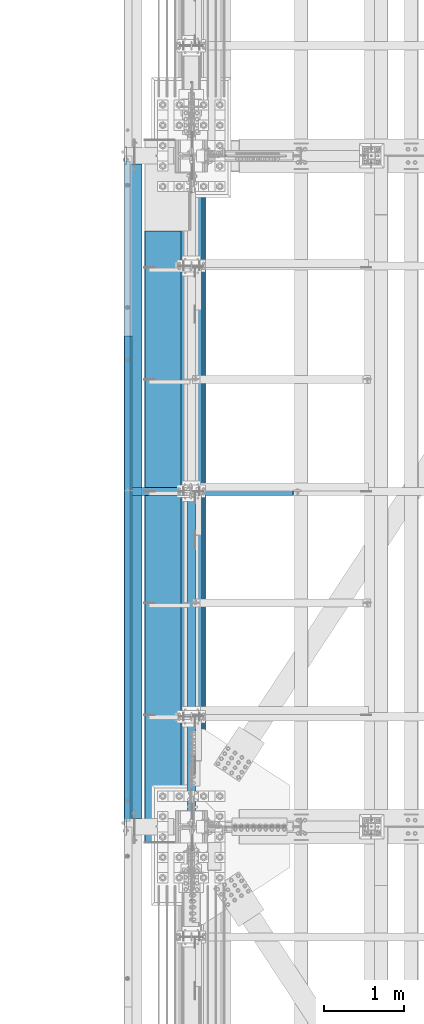
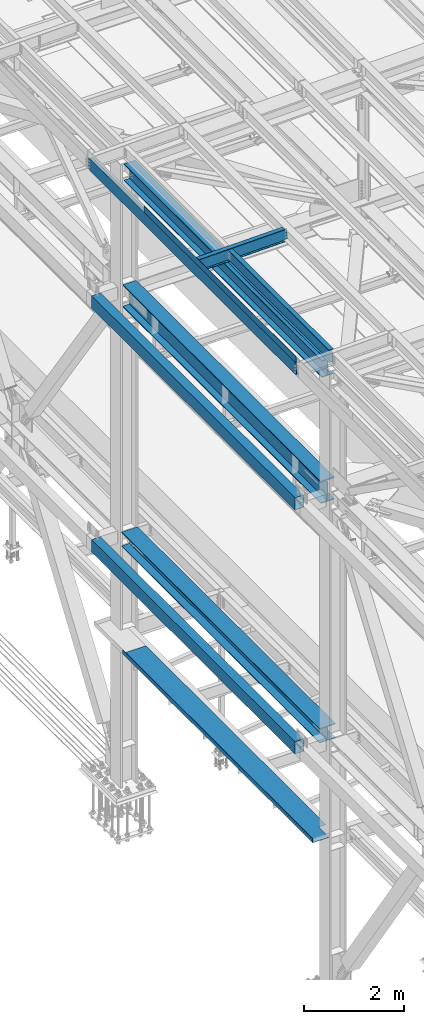
# One storey, part 1818 of 3843: 10 beams, 9 elements without a shape of their own.
"""IFC2X3 building model written with IfcOpenShell, lengths in millimetres."""

from ifc_helpers import new_model, si_unit, frame, origin_with_axes, place, context, subcontext, project, spatial, faceted_brep, material, type_object, element, aggregate, save


model = new_model("IFC2X3")

# Units and contexts
model_context = context("Model", 3, precision=1e-05, world=origin_with_axes())
body_context = subcontext(model_context, "Body", "Model", "MODEL_VIEW")
ifc_project = project(units=[si_unit("LENGTHUNIT", "METRE", prefix="MILLI"), si_unit("AREAUNIT", "SQUARE_METRE"), si_unit("VOLUMEUNIT", "CUBIC_METRE"), si_unit("MASSUNIT", "GRAM", prefix="KILO"), si_unit("TIMEUNIT", "SECOND"), si_unit("PLANEANGLEUNIT", "RADIAN"), si_unit("SOLIDANGLEUNIT", "STERADIAN"), si_unit("THERMODYNAMICTEMPERATUREUNIT", "DEGREE_CELSIUS"), si_unit("LUMINOUSINTENSITYUNIT", "LUMEN")], contexts=[model_context])

# Site, building, storey
site_placement = place(None, origin_with_axes())
site = spatial("IfcSite", under=ifc_project, at=site_placement, CompositionType="ELEMENT")
building_placement = place(site_placement, origin_with_axes())
building = spatial("IfcBuilding", under=site, at=building_placement, Name="Undefined", CompositionType="ELEMENT")
storey_placement = place(building_placement, origin_with_axes())
storey = spatial("IfcBuildingStorey", under=building, at=storey_placement, Name="Undefined", CompositionType="ELEMENT", Elevation=0.0)

# Assembly, beams
assembly_1_placement = place(storey_placement, origin_with_axes())
assembly_1 = element("IfcElementAssembly", 1, at=assembly_1_placement, inside=storey, Name="BEAM", AssemblyPlace="NOTDEFINED", PredefinedType="RIGID_FRAME")
ifc_material_1 = material(Name="STEEL/A572-50")
beam_type_1 = type_object("IfcBeamType", Name="C12X20.7", PredefinedType="NOTDEFINED")
beam_1_placement = place(assembly_1_placement, frame((35779.1150555635, 58915.2999999999, 45560.3009647419), z_axis=(-0.0211520980073474, 0.0, 0.999776269347241), x_axis=(0.0, 1.0, 0.0)))
beam_1 = element("IfcBeam", 2, at=beam_1_placement, type_object=beam_type_1, material=ifc_material_1, Name="BEAM", ObjectType="C12X20.7", context=body_context, shape_type="Brep", body=[
    faceted_brep([(15.8750000000582, 30.1624999998166, -126.999999999382), (15.8750003662499, 38.1000000000058, -127.000000023749), (53.975000190796, 38.0999999998094, -126.999999999396), (53.975000190796, 30.1624999998166, -126.999999999382), (58.8350797088351, 38.0999999998094, -127.96672992198), (58.8350797088351, 30.1624999998166, -127.966729921965), (62.955256176996, 38.0999999998021, -130.719743822439), (62.955256176996, 30.1624999998166, -130.719743822439), (65.7082700774772, 38.0999999997948, -134.839920290578), (65.7082700774772, 30.1624999998094, -134.6749274998), (66.6750000000611, 1.14757131086662e-06, -139.699999808552), (66.6750000000611, 38.0999999997948, -139.699999808603), (66.6750000000611, 38.0999999997803, -152.399999999783), (66.6750000000611, -38.1000000000931, -152.39999999971), (66.6750000000611, -38.1000000000931, -146.047459999718), (8289.92500000005, -38.0999999997948, 146.047459999805), (8289.92500000005, -38.0999999997875, 152.399999999798), (66.6750000000611, -38.0999999997875, 152.399999999798), (66.6750000000611, -38.0999999997948, 146.047459999805), (8289.92500000005, 38.1000000000859, 152.399999999725), (66.6750000000611, 38.1000000000859, 152.399999999725), (53.975000190796, 30.1625000000713, 126.999999999265), (53.975000190796, 38.100000000064, 126.999999999258), (15.8750006201954, 38.1000000000058, 126.999999975014), (15.8750000000582, 30.1625000000713, 126.999999999265), (58.8350797088351, 30.1625000000786, 127.966729921849), (58.8350797088351, 38.100000000064, 127.966729921842), (62.955256176996, 30.1625000000786, 130.719743822316), (62.955256176996, 38.1000000000568, 130.719743822301), (65.7082700774772, 30.1625000000786, 134.674927499756), (65.7082700774772, 38.1000000000713, 134.83992029044), (66.6750000000611, 1.1482770787552e-06, 139.699999808494), (66.6750000000611, 38.1000000000713, 139.699999808465), (8290.89172992263, 30.1625000000786, 134.674927499756), (8289.92500000005, 1.1482770787552e-06, 139.699999808494), (8289.92500000005, 38.1000000000713, 139.699999808465), (8290.89172992263, 38.1000000000713, 134.83992029044), (8293.64474382311, 30.1625000000786, 130.719743822316), (8293.64474382311, 38.1000000000568, 130.719743822301), (8297.76492029126, 30.1625000000786, 127.966729921849), (8297.76492029126, 38.100000000064, 127.966729921842), (8302.62499980931, 30.1625000000713, 126.999999999265), (8302.62499980931, 38.100000000064, 126.999999999258), (8340.72500000005, 30.1625000000713, 126.999999999265), (8340.72500000005, 38.100000000064, 126.999999999258), (8340.72500000005, 30.162500000064, 114.299999983516), (8340.72500000005, 30.1624999998385, -116.300000010502), (8340.72500000005, 30.1624999998166, -126.999999999382), (8340.72500000005, 38.0999999998094, -126.999999999396), (8302.62499980931, 30.1624999998166, -126.999999999382), (8302.62499980931, 38.0999999998094, -126.999999999396), (8297.76492029126, 30.1624999998166, -127.966729921965), (8297.76492029126, 38.0999999998094, -127.96672992198), (8293.64474382311, 30.1624999998166, -130.719743822439), (8293.64474382311, 38.0999999998021, -130.719743822439), (8290.89172992263, 30.1624999998094, -134.6749274998), (8290.89172992263, 38.0999999997948, -134.839920290578), (8289.92500000005, 1.14757131086662e-06, -139.699999808552), (8289.92500000005, 38.0999999997948, -139.699999808603), (8289.92500000005, -38.1000000000931, -146.047459999718), (8289.92500000005, -38.1000000000931, -152.39999999971), (8289.92500000005, 38.0999999997803, -152.399999999783), (15.8750000000582, 30.1624999998312, -116.299999999967), (15.8750000000582, 30.1625000000568, 114.299999994066)], [[[0, 1, 2, 3]], [[3, 2, 4, 5]], [[5, 4, 6, 7]], [[7, 6, 8, 9]], [[10, 11, 12, 13, 14]], [[9, 8, 11, 10]], [[15, 16, 17, 18]], [[16, 19, 20, 17]], [[21, 22, 23, 24]], [[25, 26, 22, 21]], [[27, 28, 26, 25]], [[29, 30, 28, 27]], [[31, 32, 30, 29]], [[17, 20, 32, 31, 18]], [[29, 33, 34, 15, 18, 31]], [[16, 15, 34, 35, 19]], [[33, 36, 35, 34]], [[37, 38, 36, 33]], [[39, 40, 38, 37]], [[41, 42, 40, 39]], [[43, 44, 42, 41]], [[44, 43, 45, 46, 47, 48]], [[47, 49, 50, 48]], [[51, 52, 50, 49]], [[53, 54, 52, 51]], [[55, 56, 54, 53]], [[57, 58, 56, 55]], [[59, 60, 61, 58, 57]], [[60, 59, 14, 13]], [[61, 60, 13, 12]], [[6, 4, 2, 1, 23, 22, 26, 28, 30, 32, 20, 19, 35, 36, 38, 40, 42, 44, 48, 50, 52, 54, 56, 58, 61, 12, 11, 8]], [[62, 63, 24, 23, 1, 0]], [[55, 53, 51, 49, 47, 46, 45, 43, 41, 39, 37, 33, 29, 27, 25, 21, 24, 63, 62, 0, 3, 5, 7, 9]], [[59, 57, 55, 9, 10, 14]]]),
])
ifc_material_2 = material(Name="STEEL/A36")
beam_type_2 = type_object("IfcBeamType", PredefinedType="NOTDEFINED")
beam_2_placement = place(assembly_1_placement, frame((35839.3101110204, 61979.175, 45717.1843160684), z_axis=(0.0, -1.0, 0.0), x_axis=(-0.999776270257024, 0.0, -0.0211520550054595)))
beam_2 = element("IfcBeam", 3, at=beam_2_placement, type_object=beam_type_2, material=ifc_material_2, Name="BENT_PLATE", context=body_context, shape_type="Brep", body=[
    faceted_brep([(-3.50355549016967e-07, -3.17499999742722, -3048.00000001723), (3.50421032635495e-07, -3.17500000260043, 3048.00000001724), (3.5035191103816e-07, 3.17499999739084, 3048.00000001724), (-3.50424670614302e-07, 3.17500000256405, -3048.00000001723), (101.599999864371, 3.17499999856227, 3048.00000000522), (101.599998739839, 3.17500000373548, -3048.00000002925), (95.249998765099, -3.17499999632128, -3048.00000002851), (95.2499998896274, -3.17500000149448, 3048.00000000597), (101.600000309205, -161.925000875126, 3047.9999999938), (101.599999608374, -161.925000446165, -3048.00000004067), (95.2500003092064, -161.925000900388, 3047.99999999456), (95.2499996083752, -161.925000471427, -3048.00000003992)], [[[0, 1, 2, 3]], [[3, 2, 4, 5]], [[1, 0, 6, 7]], [[5, 4, 8, 9]], [[4, 2, 1, 7, 10, 8]], [[7, 6, 11, 10]], [[6, 0, 3, 5, 9, 11]], [[10, 11, 9, 8]]]),
])
aggregate(assembly_1, [beam_2, beam_1])

# Assembly, beam
assembly_2_placement = place(storey_placement, origin_with_axes())
assembly_2 = element("IfcElementAssembly", 4, at=assembly_2_placement, inside=storey, Name="BEAM", AssemblyPlace="NOTDEFINED", PredefinedType="RIGID_FRAME")
ifc_material_3 = material(Name="STEEL/A992")
beam_type_3 = type_object("IfcBeamType", Name="W21X101", PredefinedType="NOTDEFINED")
beam_3_placement = place(assembly_2_placement, frame((36576.0, 58915.3, 42197.3375), z_axis=(0.0, 0.0, 1.0), x_axis=(0.0, 1.0, 0.0)))
beam_3 = element("IfcBeam", 5, at=beam_3_placement, type_object=beam_type_3, material=ifc_material_3, Name="BEAM", ObjectType="W21X101", context=body_context, shape_type="Brep", body=[
    faceted_brep([(221.464601116095, -155.574999999997, 271.462500000001), (221.464601116095, 155.574999999997, 271.462500000001), (209.550000000017, 155.574999999997, 250.824999999997), (209.550000000017, 6.34999999999854, 250.824999999997), (209.550000000017, -6.34999999999854, 250.824999999997), (209.550000000017, -155.574999999997, 250.824999999997), (8143.87499999999, 6.34999999999854, -250.824999999997), (8143.87499999999, 147.637499999997, -250.824999999997), (8143.87499999999, 155.574999999997, -250.824999999997), (212.724999999999, 155.574999999997, -250.824999999997), (212.724999999999, 6.34999999999854, -250.824999999997), (8143.87499999999, -155.574999999997, -271.462500000001), (8143.87499999999, -155.574999999997, -250.824999999997), (212.724999999999, -155.574999999997, -250.824999999997), (212.724999999999, -155.574999999997, -271.462500000001), (8143.87499999999, 155.574999999997, -271.462500000001), (8143.87499999999, 147.637499999997, -271.462500000001), (8143.87499999999, -147.637499999997, -271.462500000001), (212.724999999999, 155.574999999997, -271.462500000001), (8143.87499999999, 6.34999999999854, 250.824999999997), (8143.87499999999, 147.637499999997, 250.824999999997), (8143.87499999999, 155.574999999997, 250.824999999997), (8143.87499999999, 155.574999999997, 271.462500000001), (8143.87499999999, 147.637499999997, 271.462500000001), (8143.87499999999, -147.637499999997, 271.462500000001), (8143.87499999999, -155.574999999997, 271.462500000001), (8143.87499999999, -155.574999999997, 250.824999999997), (8143.87499999999, -147.637499999997, 250.824999999997), (8143.87499999999, -6.34999999999854, 250.824999999997), (8143.87499999999, -6.34999999999854, 215.052499999998), (8143.87499999999, -6.34999999999854, -180.127499999995), (8143.87499999999, -6.34999999999854, -250.824999999997), (8143.87499999999, -147.637499999997, -250.824999999997), (209.550000000017, 6.34999999999854, 250.428), (209.550000000017, -6.34999999999854, 250.428), (244.474999999999, 6.34999999999854, 250.428), (244.474999999999, -6.34999999999854, 250.428), (289.859905435071, 6.34999999999854, 234.406795689014), (289.859905435071, -6.34999999999854, 234.406795689014), (294.149267898792, 6.34999999999854, 231.347328818971), (294.149267898792, -6.34999999999854, 231.347328818971), (296.156122181892, 6.34999999999854, 226.475829690324), (296.156122181892, -6.34999999999854, 226.475829690324), (295.266438807761, 6.34999999999854, 221.282812131351), (295.266438807761, -6.34999999999854, 221.282812131351), (291.752430772212, 6.34999999999854, 217.357163726287), (291.752430772212, -6.34999999999854, 217.357163726287), (286.689265581459, 6.34999999999854, 215.900000000001), (286.689265581459, -6.34999999999854, 215.900000000001), (212.724999999999, 6.34999999999854, 215.900000000001), (212.724999999999, -6.34999999999854, 215.900000000001), (212.724999999999, -6.34999999999854, -250.824999999997)], [[[0, 1, 2, 3, 4, 5]], [[6, 7, 8, 9, 10]], [[11, 12, 13, 14]], [[15, 16, 17, 11, 14, 18]], [[8, 15, 18, 9]], [[7, 6, 19, 20, 21, 22, 23, 24, 25, 26, 27, 28, 29, 30, 31, 32, 12, 11, 17, 16, 15, 8]], [[26, 25, 0, 5]], [[28, 27, 26, 5, 4]], [[33, 34, 4, 3]], [[35, 36, 34, 33]], [[36, 35, 37, 38]], [[38, 37, 39, 40]], [[40, 39, 41, 42]], [[42, 41, 43, 44]], [[44, 43, 45, 46]], [[46, 45, 47, 48]], [[48, 47, 49, 50]], [[31, 30, 29, 28, 4, 34, 36, 38, 40, 42, 44, 46, 48, 50, 51]], [[12, 32, 31, 51, 13]], [[50, 49, 10, 9, 18, 14, 13, 51]], [[47, 45, 43, 41, 39, 37, 35, 33, 3, 19, 6, 10, 49]], [[21, 20, 19, 3, 2]], [[22, 21, 2, 1]], [[25, 24, 23, 22, 1, 0]]]),
])
aggregate(assembly_2, [beam_3])

assembly_3_placement = place(storey_placement, origin_with_axes())
assembly_3 = element("IfcElementAssembly", 6, at=assembly_3_placement, inside=storey, Name="GIRT", AssemblyPlace="NOTDEFINED", PredefinedType="RIGID_FRAME")
ifc_material_4 = material()
beam_type_4 = type_object("IfcBeamType", Name="HSS12X8X3/8", PredefinedType="NOTDEFINED")
beam_4_placement = place(assembly_3_placement, frame((35861.625, 58915.3, 42214.8), z_axis=(0.0, 0.0, 1.0), x_axis=(0.0, 1.0, 0.0)))
beam_4 = element("IfcBeam", 7, at=beam_4_placement, type_object=beam_type_4, material=ifc_material_4, Name="GIRT", ObjectType="HSS12X8X3/8", context=body_context, shape_type="Brep", body=[
    faceted_brep([(8253.41249999999, 101.599999999999, -152.400000000001), (8253.41249999999, -101.599999999999, -152.400000000001), (103.1875, -101.600000000006, -152.400000000001), (103.1875, 101.600000000006, -152.400000000001), (8253.41249999999, 101.599999999999, 152.400000000001), (103.1875, 101.600000000006, 152.400000000001), (8253.41249999999, -101.599999999999, 152.400000000001), (103.1875, -101.600000000006, 152.400000000001), (8253.41249999999, 92.0749999999971, -142.875), (8253.41249999999, -92.0749999999971, -142.875), (8253.41249999999, -92.0749999999971, 142.875), (8253.41249999999, 92.0749999999971, 142.875), (103.1875, -92.0749999999971, 142.875), (103.1875, 92.0749999999971, 142.875), (103.1875, 92.0749999999971, -142.875), (103.1875, -92.0749999999971, -142.875)], [[[0, 1, 2, 3]], [[4, 0, 3, 5]], [[6, 4, 5, 7]], [[1, 6, 7, 2]], [[0, 4, 6, 1], [8, 9, 10, 11]], [[11, 10, 12, 13]], [[8, 11, 13, 14]], [[9, 8, 14, 15]], [[10, 9, 15, 12]], [[3, 2, 7, 5], [14, 13, 12, 15]]]),
])
aggregate(assembly_3, [beam_4])

assembly_4_placement = place(storey_placement, origin_with_axes())
assembly_4 = element("IfcElementAssembly", 8, at=assembly_4_placement, inside=storey, Name="GIRT", AssemblyPlace="NOTDEFINED", PredefinedType="RIGID_FRAME")
beam_5_placement = place(assembly_4_placement, frame((35861.625, 58915.3, 36252.15), z_axis=(0.0, 0.0, 1.0), x_axis=(0.0, 1.0, 0.0)))
beam_5 = element("IfcBeam", 9, at=beam_5_placement, type_object=beam_type_4, material=ifc_material_4, Name="GIRT", ObjectType="HSS12X8X3/8", context=body_context, shape_type="Brep", body=[
    faceted_brep([(8253.41249999999, 101.599999999999, -152.400000000001), (8253.41249999999, -101.599999999999, -152.400000000001), (103.1875, -101.600000000006, -152.400000000001), (103.1875, 101.600000000006, -152.400000000001), (8253.41249999999, 101.599999999999, 152.400000000001), (103.1875, 101.600000000006, 152.400000000001), (8253.41249999999, -101.599999999999, 152.400000000001), (103.1875, -101.600000000006, 152.400000000001), (8253.41249999999, 92.0749999999971, -142.875), (8253.41249999999, -92.0749999999971, -142.875), (8253.41249999999, -92.0749999999971, 142.875), (8253.41249999999, 92.0749999999971, 142.875), (103.1875, -92.0749999999971, 142.875), (103.1875, 92.0749999999971, 142.875), (103.1875, 92.0749999999971, -142.875), (103.1875, -92.0749999999971, -142.875)], [[[0, 1, 2, 3]], [[4, 0, 3, 5]], [[6, 4, 5, 7]], [[1, 6, 7, 2]], [[0, 4, 6, 1], [8, 9, 10, 11]], [[11, 10, 12, 13]], [[8, 11, 13, 14]], [[9, 8, 14, 15]], [[10, 9, 15, 12]], [[3, 2, 7, 5], [14, 13, 12, 15]]]),
])
aggregate(assembly_4, [beam_5])

assembly_5_placement = place(storey_placement, origin_with_axes())
assembly_5 = element("IfcElementAssembly", 10, at=assembly_5_placement, inside=storey, Name="BEAM", AssemblyPlace="NOTDEFINED", PredefinedType="RIGID_FRAME")
beam_type_5 = type_object("IfcBeamType", Name="W12X19", PredefinedType="NOTDEFINED")
beam_6_placement = place(assembly_5_placement, frame((36575.9999999593, 58915.3, 45575.607129369), z_axis=(0.0, 0.0, 1.0), x_axis=(0.0, 1.0, 0.0)))
beam_6 = element("IfcBeam", 11, at=beam_6_placement, type_object=beam_type_5, material=ifc_material_3, Name="BEAM", ObjectType="W12X19", context=body_context, shape_type="Brep", body=[
    faceted_brep([(15.8750000000146, -3.17500000000291, -128.587499998961), (15.8750000000146, 3.17500000000291, -128.587499998961), (53.9750001907523, 3.17500000000291, -128.587499998961), (53.9750001907523, -3.17500000000291, -128.587499998961), (58.8350797087915, 3.17500000000291, -129.554229921552), (58.8350797087915, -3.17500000000291, -129.554229921552), (62.9552561769524, 3.17500000000291, -132.307243822026), (62.9552561769524, -3.17500000000291, -132.307243822026), (65.7082700774336, 3.17500000000291, -136.42742029018), (65.7082700774336, -3.17500000000291, -136.42742029018), (66.6750000000175, -3.17500000000291, -141.287499808226), (66.6750000000175, 3.17500000000291, -141.287499808226), (66.6750000000175, 3.17500000000291, -144.462500000001), (66.6750000000175, 50.8000000000029, -144.462500000001), (66.6750000000175, 50.8000000000029, -153.987500000003), (66.6749999999811, -50.8000000000029, -153.999459048515), (66.6750000000175, -50.8000000000029, -144.462500000001), (66.6750000000175, -3.17500000000291, -144.462500000001), (4111.62499999991, 50.8000000000029, 144.462500000001), (4111.62499999991, 3.17500000000291, 144.462500000001), (66.6750000000175, 3.17500000000291, 144.462500000001), (66.6750000000175, 50.8000000000029, 144.462500000001), (53.9750001907523, -3.17500000000291, 128.587500001042), (53.9750001907523, 3.17500000000291, 128.587500001042), (15.8750000000146, 3.17500000000291, 128.587500001042), (15.8750000000146, -3.17500000000291, 128.587500001042), (58.8350797087915, -3.17500000000291, 129.554229923633), (58.8350797087915, 3.17500000000291, 129.554229923633), (62.9552561769524, -3.17500000000291, 132.307243824107), (62.9552561769524, 3.17500000000291, 132.307243824107), (65.7082700774336, -3.17500000000291, 136.427420292261), (65.7082700774336, 3.17500000000291, 136.427420292261), (66.6750000000175, -3.17500000000291, 141.287499810307), (66.6750000000175, 3.17500000000291, 141.287499810307), (4111.62499999991, -50.8000000000029, 153.987500000003), (4111.62499999991, 50.8000000000029, 153.987500000003), (66.6750000000175, 50.8000000000029, 153.987500000003), (66.6749999999811, -50.8000000000029, 154.207890303915), (4111.62499999991, -50.8000000000029, 144.462500000001), (66.6750000000175, -50.8000000000029, 144.462500000001), (4111.62499999991, -3.17500000000291, 144.462500000001), (66.6750000000175, -3.17500000000291, 144.462500000001), (4111.62499999991, -3.17500000000291, 141.287499810329), (4111.62499999991, 3.17500000000291, 141.287499810329), (4112.5917299225, -3.17500000000291, 136.427420292282), (4112.5917299225, 3.17500000000291, 136.427420292282), (4115.34474382298, -3.17500000000291, 132.307243824129), (4115.34474382298, 3.17500000000291, 132.307243824129), (4119.46492029114, -3.17500000000291, 129.554229923655), (4119.46492029114, 3.17500000000291, 129.554229923655), (4124.32499980918, -3.17500000000291, 128.587500001064), (4124.32499980918, 3.17500000000291, 128.587500001064), (4162.42499999992, -3.17500000000291, 128.587500001064), (4162.42499999992, 3.17500000000291, 128.587500001064), (4162.42499999992, 3.17500000000291, -114.712499998423), (4162.42499999992, 3.17500000000291, 115.887500001576), (4162.42499999992, -3.17500000000291, -128.587499998939), (4162.42499999992, 3.17500000000291, -128.587499998939), (4124.32499980918, -3.17500000000291, -128.587499998939), (4124.32499980918, 3.17500000000291, -128.587499998939), (4119.46492029114, -3.17500000000291, -129.55422992153), (4119.46492029114, 3.17500000000291, -129.55422992153), (4115.34474382298, -3.17500000000291, -132.307243822004), (4115.34474382298, 3.17500000000291, -132.307243822004), (4112.5917299225, -3.17500000000291, -136.427420290158), (4112.5917299225, 3.17500000000291, -136.427420290158), (4111.62499999991, -3.17500000000291, -141.287499808204), (4111.62499999991, 3.17500000000291, -141.287499808204), (4111.62499999991, -3.17500000000291, -144.462500000001), (4111.62499999991, -50.8000000000029, -144.462500000001), (4111.62499999991, -50.8000000000029, -153.987500000003), (4111.62499999991, 50.8000000000029, -153.987500000003), (4111.62499999991, 50.8000000000029, -144.462500000001), (4111.62499999991, 3.17500000000291, -144.462500000001), (15.8750000000146, 3.17500000000291, -114.712499998386), (15.8750000000146, 3.17500000000291, 115.887500001612)], [[[0, 1, 2, 3]], [[3, 2, 4, 5]], [[5, 4, 6, 7]], [[7, 6, 8, 9]], [[10, 11, 12, 13, 14, 15, 16, 17]], [[9, 8, 11, 10]], [[18, 19, 20, 21]], [[22, 23, 24, 25]], [[26, 27, 23, 22]], [[28, 29, 27, 26]], [[30, 31, 29, 28]], [[32, 33, 31, 30]], [[34, 35, 36, 37]], [[38, 34, 37, 39]], [[40, 38, 39, 41]], [[37, 36, 21, 20, 33, 32, 41, 39]], [[35, 18, 21, 36]], [[34, 38, 40, 42, 43, 19, 18, 35]], [[44, 45, 43, 42]], [[46, 47, 45, 44]], [[48, 49, 47, 46]], [[50, 51, 49, 48]], [[52, 53, 51, 50]], [[54, 55, 53, 52, 56, 57]], [[56, 58, 59, 57]], [[60, 61, 59, 58]], [[62, 63, 61, 60]], [[64, 65, 63, 62]], [[66, 67, 65, 64]], [[68, 69, 70, 71, 72, 73, 67, 66]], [[69, 68, 17, 16]], [[70, 69, 16, 15]], [[71, 70, 15, 14]], [[72, 71, 14, 13]], [[73, 72, 13, 12]], [[6, 4, 2, 1, 74, 75, 24, 23, 27, 29, 31, 33, 20, 19, 43, 45, 47, 49, 51, 53, 55, 54, 57, 59, 61, 63, 65, 67, 73, 12, 11, 8]], [[25, 24, 75, 74, 1, 0]], [[68, 66, 64, 62, 60, 58, 56, 52, 50, 48, 46, 44, 42, 40, 41, 32, 30, 28, 26, 22, 25, 0, 3, 5, 7, 9, 10, 17]]]),
])
aggregate(assembly_5, [beam_6])

assembly_6_placement = place(storey_placement, origin_with_axes())
assembly_6 = element("IfcElementAssembly", 12, at=assembly_6_placement, inside=storey, Name="BEAM", AssemblyPlace="NOTDEFINED", PredefinedType="RIGID_FRAME")
beam_7_placement = place(assembly_6_placement, frame((35741.0571586919, 63093.5999999999, 45557.9079249889), z_axis=(-0.0211520980073474, 0.0, 0.999776269347241), x_axis=(0.999776270257024, 0.0, 0.0211520550054619)))
beam_7 = element("IfcBeam", 13, at=beam_7_placement, type_object=beam_type_5, material=ifc_material_3, Name="BEAM", ObjectType="W12X19", context=body_context, shape_type="Brep", body=[
    faceted_brep([(20.6374979119428, -3.17500000000291, -128.587500021946), (20.6374979119428, 3.17500000000291, -128.587500021946), (84.1374979491229, 3.17500000000291, -128.587500085479), (84.1374979491229, -3.17500000000291, -128.587500085479), (88.9975774661289, 3.17500000000291, -129.554230012938), (88.9975774661289, -3.17500000000291, -129.554230012938), (93.1177539315104, 3.17500000000291, -132.307243917545), (93.1177539315104, -3.17500000000291, -132.307243917545), (95.8707678278151, 3.17500000000291, -136.427420388471), (95.8707678278151, -3.17500000000291, -136.427420388471), (96.8374977455387, -3.17500000000291, -141.287499907492), (96.8374977455387, 3.17500000000291, -141.287499907492), (96.8374977423518, 3.17500000000291, -144.462499999776), (96.8374977423518, 50.8000000000029, -144.462499999776), (96.8374977328203, 50.8000000000029, -153.987499999792), (96.8374977328203, -50.8000000000029, -153.987499999792), (96.8374977423518, -50.8000000000029, -144.462499999776), (96.8374977423518, -3.17500000000291, -144.462499999776), (2105.41812082298, 50.8000000000029, 144.462500001886), (2105.41812082298, 3.17500000000291, 144.462500001886), (96.8374980314547, 3.17500000000291, 144.462500000489), (96.8374980314547, 50.8000000000029, 144.462500000489), (84.1374982064444, -3.17500000000291, 128.587499915513), (84.1374982064444, 3.17500000000291, 128.587499915513), (20.637499711811, 3.17500000000291, 128.587499979069), (20.637499711811, -3.17500000000291, 128.587499979069), (88.9975777254003, -3.17500000000291, 129.554229833244), (88.9975777254003, 3.17500000000291, 129.554229833244), (93.1177541962679, -3.17500000000291, 132.307243729607), (93.1177541962679, 3.17500000000291, 132.307243729607), (95.8707681008382, -3.17500000000291, 136.427420195025), (95.8707681008382, 3.17500000000291, 136.427420195025), (96.8374980282824, -3.17500000000291, 141.287499712118), (96.8374980282824, 3.17500000000291, 141.287499712118), (2105.41812082297, -50.8000000000029, 153.987500001873), (2105.41812082297, 50.8000000000029, 153.987500001873), (96.8374980410008, 50.8000000000029, 153.987500000498), (96.8374980410154, -50.8000000000029, 153.987499285155), (2105.41812082298, -50.8000000000029, 144.462500001886), (96.8374980314547, -50.8000000000029, 144.462500000489), (2105.41812082298, -3.17500000000291, 144.462500001886), (96.8374980314547, -3.17500000000291, 144.462500000489), (2105.41812082299, -3.17500000000291, 141.287499819417), (2105.41812082299, 3.17500000000291, 141.287499819417), (2106.38485074557, -3.17500000000291, 136.427420301385), (2106.38485074557, 3.17500000000291, 136.427420301385), (2109.13786464603, -3.17500000000291, 132.307243833253), (2109.13786464603, 3.17500000000291, 132.307243833253), (2113.25804111418, -3.17500000000291, 129.554229932794), (2113.25804111418, 3.17500000000291, 129.554229932794), (2118.11812063219, -3.17500000000291, 128.587500010217), (2118.11812063219, 3.17500000000291, 128.587500010217), (2187.96812082909, -3.17500000000291, 128.58750001029), (2187.96812082909, 3.17500000000291, 128.58750001029), (2187.96812084018, 3.17500000000291, -114.712499998102), (2187.96812084017, 3.17500000000291, 115.887499995013), (2187.96812082909, -3.17500000000291, -128.587499988374), (2187.96812082909, 3.17500000000291, -128.587499988374), (2118.11812063261, -3.17500000000291, -128.58749998844), (2118.11812063261, 3.17500000000291, -128.58749998844), (2113.25804111459, -3.17500000000291, -129.554229911031), (2113.25804111459, 3.17500000000291, -129.554229911031), (2109.13786464647, -3.17500000000291, -132.307243811505), (2109.13786464647, 3.17500000000291, -132.307243811505), (2106.384850746, -3.17500000000291, -136.427420279637), (2106.384850746, 3.17500000000291, -136.427420279637), (2105.41812082342, -3.17500000000291, -141.287499797661), (2105.41812082342, 3.17500000000291, -141.287499797661), (2105.41812082343, -3.17500000000291, -144.462499997644), (2105.41812082343, -50.8000000000029, -144.462499997644), (2105.41812082344, -50.8000000000029, -153.987499997631), (2105.41812082344, 50.8000000000029, -153.987499997631), (2105.41812082343, 50.8000000000029, -144.462499997644), (2105.41812082343, 3.17500000000291, -144.462499997644), (20.6374980090477, 3.17500000000291, -114.712499752241), (20.6374996229279, 3.17500000000291, 115.88750024372)], [[[0, 1, 2, 3]], [[3, 2, 4, 5]], [[5, 4, 6, 7]], [[7, 6, 8, 9]], [[10, 11, 12, 13, 14, 15, 16, 17]], [[9, 8, 11, 10]], [[18, 19, 20, 21]], [[22, 23, 24, 25]], [[26, 27, 23, 22]], [[28, 29, 27, 26]], [[30, 31, 29, 28]], [[32, 33, 31, 30]], [[34, 35, 36, 37]], [[38, 34, 37, 39]], [[40, 38, 39, 41]], [[37, 36, 21, 20, 33, 32, 41, 39]], [[35, 18, 21, 36]], [[34, 38, 40, 42, 43, 19, 18, 35]], [[44, 45, 43, 42]], [[46, 47, 45, 44]], [[48, 49, 47, 46]], [[50, 51, 49, 48]], [[52, 53, 51, 50]], [[54, 55, 53, 52, 56, 57]], [[56, 58, 59, 57]], [[60, 61, 59, 58]], [[62, 63, 61, 60]], [[64, 65, 63, 62]], [[66, 67, 65, 64]], [[68, 69, 70, 71, 72, 73, 67, 66]], [[69, 68, 17, 16]], [[70, 69, 16, 15]], [[71, 70, 15, 14]], [[72, 71, 14, 13]], [[73, 72, 13, 12]], [[6, 4, 2, 1, 74, 75, 24, 23, 27, 29, 31, 33, 20, 19, 43, 45, 47, 49, 51, 53, 55, 54, 57, 59, 61, 63, 65, 67, 73, 12, 11, 8]], [[25, 24, 75, 74, 1, 0]], [[68, 66, 64, 62, 60, 58, 56, 52, 50, 48, 46, 44, 42, 40, 41, 32, 30, 28, 26, 22, 25, 0, 3, 5, 7, 9, 10, 17]]]),
])
aggregate(assembly_6, [beam_7])

assembly_7_placement = place(storey_placement, origin_with_axes())
assembly_7 = element("IfcElementAssembly", 14, at=assembly_7_placement, inside=storey, Name="BEAM", AssemblyPlace="NOTDEFINED", PredefinedType="RIGID_FRAME")
beam_type_6 = type_object("IfcBeamType", PredefinedType="NOTDEFINED")
beam_8_placement = place(assembly_7_placement, frame((36537.9000000002, 62525.275, 34039.175), z_axis=(0.0, -1.0, 0.0), x_axis=(-1.0, 0.0, 0.0)))
beam_8 = element("IfcBeam", 15, at=beam_8_placement, type_object=beam_type_6, material=ifc_material_2, Name="BENT_PLATE", context=body_context, shape_type="Brep", body=[
    faceted_brep([(168.275000000205, -3.17500000000291, 3397.24999999999), (168.275000000205, 3.17500000000291, 3397.24999999999), (0.0, 3.17500000000291, 3397.24999999999), (0.0, -3.17500000000291, 3397.24999999999), (168.275000000205, -3.17500000000291, 3810.0), (168.275000000205, 3.17500000000291, 3810.0), (539.749975586143, -3.17500000000291, -3810.0), (0.0, -3.17500000000291, -3810.0), (0.0, 3.17500000000291, -3810.0), (546.099973958539, 3.17500000000291, -3810.0), (546.10000000021, -98.424998372182, -3810.0), (539.750000000204, -98.4249999997846, -3810.0), (546.099973958539, 3.17500000000291, 3810.0), (546.10000000021, -98.424998372182, 3810.0), (539.750000000204, -98.4249999997846, 3810.0), (539.749975586143, -3.17500000000291, 3810.0)], [[[0, 1, 2, 3]], [[4, 5, 1, 0]], [[6, 7, 8, 9, 10, 11]], [[9, 12, 13, 10]], [[14, 11, 10, 13]], [[15, 6, 11, 14]], [[3, 7, 6, 15, 4, 0]], [[8, 7, 3, 2]], [[12, 9, 8, 2, 1, 5]], [[15, 14, 13, 12, 5, 4]]]),
])
aggregate(assembly_7, [beam_8])

assembly_8_placement = place(storey_placement, origin_with_axes())
assembly_8 = element("IfcElementAssembly", 16, at=assembly_8_placement, inside=storey, Name="BEAM", AssemblyPlace="NOTDEFINED", PredefinedType="RIGID_FRAME")
beam_type_7 = type_object("IfcBeamType", Name="W16X67", PredefinedType="NOTDEFINED")
beam_9_placement = place(assembly_8_placement, frame((36576.0000000463, 58915.3, 45210.4125000006), z_axis=(0.0, 0.0, 1.0), x_axis=(0.0, 1.0, 0.0)))
beam_9 = element("IfcBeam", 17, at=beam_9_placement, type_object=beam_type_7, material=ifc_material_3, Name="BEAM", ObjectType="W16X67", context=body_context, shape_type="Brep", body=[
    faceted_brep([(212.724999999991, -130.175000000003, -207.962500000001), (212.724999999991, 130.175000000003, -207.962500000001), (8143.87500000003, 130.175000000003, -207.962500000001), (8143.87500000003, -130.175000000003, -207.962500000001), (212.724999999991, -130.175000000003, -190.5), (212.724999999991, -4.76249999999709, -190.5), (212.724999999991, -4.76249999999709, -142.027500000993), (212.724999999991, -4.76249999999709, 176.952499999003), (212.724999999991, -4.76249999999709, 190.5), (212.724999999991, -130.175000000003, 190.5), (212.724999999991, -130.175000000003, 207.962500000001), (212.724999999991, 130.175000000003, 207.962500000001), (212.724999999991, 130.175000000003, 190.5), (212.724999999991, 4.76249999999709, 190.5), (212.724999999991, 4.76249999999709, -190.5), (212.724999999991, 130.175000000003, -190.5), (8143.87500000003, -130.175000000003, -190.5), (8143.87500000003, -4.76249999999709, -190.5), (8143.87500000003, -4.76249999999709, -142.02750001238), (8143.87500000003, -4.76249999999709, 176.952499987616), (8143.87500000003, -4.76249999999709, 190.5), (8143.87500000003, -130.175000000003, 190.5), (8143.87500000003, -130.175000000003, 207.962500000001), (8143.87500000003, 130.175000000003, 207.962500000001), (8143.87500000003, 130.175000000003, 190.5), (8143.87500000003, 4.76249999999709, 190.5), (8143.87500000003, 4.76249999999709, -190.5), (8143.87500000003, 130.175000000003, -190.5)], [[[0, 1, 2, 3]], [[0, 4, 5, 6, 7, 8, 9, 10, 11, 12, 13, 14, 15, 1]], [[5, 4, 16, 17]], [[8, 7, 6, 5, 17, 18, 19, 20]], [[9, 8, 20, 21]], [[10, 9, 21, 22]], [[11, 10, 22, 23]], [[12, 11, 23, 24]], [[13, 12, 24, 25]], [[14, 13, 25, 26]], [[15, 14, 26, 27]], [[1, 15, 27, 2]], [[26, 25, 24, 23, 22, 21, 20, 19, 18, 17, 16, 3, 2, 27]], [[4, 0, 3, 16]]]),
])
aggregate(assembly_8, [beam_9])

assembly_9_placement = place(storey_placement, origin_with_axes())
assembly_9 = element("IfcElementAssembly", 18, at=assembly_9_placement, inside=storey, Name="BEAM", AssemblyPlace="NOTDEFINED", PredefinedType="RIGID_FRAME")
beam_type_8 = type_object("IfcBeamType", Name="W14X90", PredefinedType="NOTDEFINED")
beam_10_placement = place(assembly_9_placement, frame((36576.0, 58915.3, 36258.5), z_axis=(0.0, 0.0, 1.0), x_axis=(0.0, 1.0, 0.0)))
beam_10 = element("IfcBeam", 19, at=beam_10_placement, type_object=beam_type_8, material=ifc_material_3, Name="BEAM", ObjectType="W14X90", context=body_context, shape_type="Brep", body=[
    faceted_brep([(212.724999999991, 184.150000000001, -177.800000000003), (212.724999999991, 184.150000000001, -160.337500000001), (8143.87500000002, 184.150000000001, -160.337500000001), (8143.87500000002, 184.150000000001, -177.800000000003), (212.724999999991, 5.55625000000146, -160.337500000001), (8143.87500000002, 5.55625000000146, -160.337500000001), (212.724999999991, 5.55625000000146, 160.337500000001), (8143.87500000002, 5.55625000000146, 160.337500000001), (212.724999999991, 184.150000000001, 160.337500000001), (8143.87500000002, 184.150000000001, 160.337500000001), (212.724999999991, 184.150000000001, 177.800000000003), (8143.87500000002, 184.150000000001, 177.800000000003), (212.724999999991, -184.150000000001, 177.800000000003), (8143.87500000002, -184.150000000001, 177.800000000003), (212.724999999991, -184.150000000001, 160.337500000001), (8143.87500000002, -184.150000000001, 160.337500000001), (212.724999999991, -5.55625000000146, 160.337500000001), (8143.87500000002, -5.55625000000146, 160.337500000001), (212.724999999991, -5.55625000000146, -160.337500000001), (8143.87500000002, -5.55625000000146, -160.337500000001), (212.724999999991, -184.150000000001, -160.337500000001), (8143.87500000002, -184.150000000001, -160.337500000001), (212.724999999991, -184.150000000001, -177.800000000003), (8143.87500000002, -184.150000000001, -177.800000000003)], [[[0, 1, 2, 3]], [[1, 4, 5, 2]], [[4, 6, 7, 5]], [[6, 8, 9, 7]], [[8, 10, 11, 9]], [[10, 12, 13, 11]], [[12, 14, 15, 13]], [[14, 16, 17, 15]], [[16, 18, 19, 17]], [[18, 20, 21, 19]], [[20, 22, 23, 21]], [[22, 0, 3, 23]], [[5, 7, 9, 11, 13, 15, 17, 19, 21, 23, 3, 2]], [[22, 20, 18, 16, 14, 12, 10, 8, 6, 4, 1, 0]]]),
])
aggregate(assembly_9, [beam_10])

save(model, "model.ifc")
